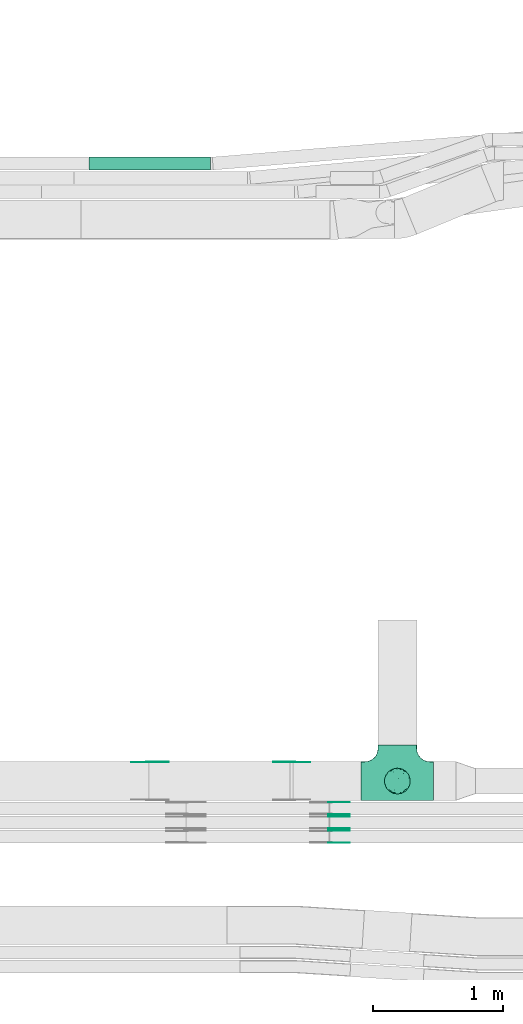
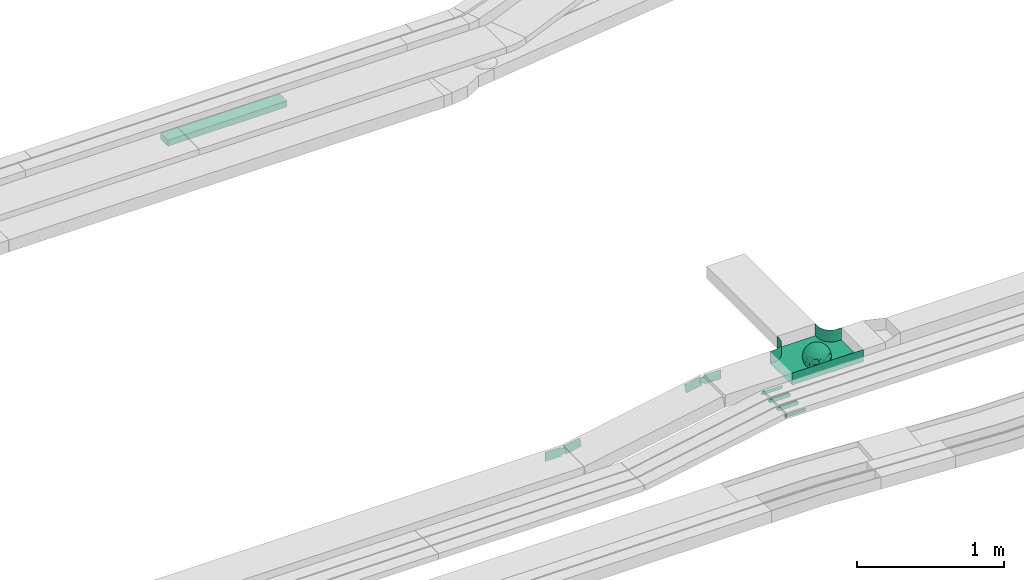
# One storey, part 12 of 32: 11 flow fittings, 1 flow segment.
"""IFC2X3 building model written with IfcOpenShell, lengths in millimetres."""

from ifc_helpers import new_model, entity, si_unit, converted_unit, derived_unit, direction, frame, frame_2d, origin, origin_2d_with_axis, place, context, subcontext, project, spatial, polyline, circle_curve, parameter, trimmed, segment, composite_curve, rectangle, outline, extrude, faceted_brep, source, transform, mapped, material, material_list, type_object, type_shapes, element, save


model = new_model("IFC2X3")

# Units and contexts
model_context = context("Model", 3, precision=0.01, world=origin(), true_north=direction((6.12303176911189e-17, 1.0)))
body_context = subcontext(model_context, "Body", "Model", "MODEL_VIEW")
ifc_project = project(units=[si_unit("LENGTHUNIT", "METRE", prefix="MILLI"), si_unit("AREAUNIT", "SQUARE_METRE"), si_unit("VOLUMEUNIT", "CUBIC_METRE"), converted_unit("PLANEANGLEUNIT", "DEGREE", entity("IfcRatioMeasure", 0.0174532925199433), si_unit("PLANEANGLEUNIT", "RADIAN"), dimensions=[0, 0, 0, 0, 0, 0, 0]), si_unit("MASSUNIT", "GRAM", prefix="KILO"), derived_unit("MASSDENSITYUNIT", [(si_unit("MASSUNIT", "GRAM", prefix="KILO"), 1), (si_unit("LENGTHUNIT", "METRE"), -3)]), derived_unit("MOMENTOFINERTIAUNIT", [(si_unit("LENGTHUNIT", "METRE"), 4)]), si_unit("TIMEUNIT", "SECOND"), si_unit("FREQUENCYUNIT", "HERTZ"), si_unit("THERMODYNAMICTEMPERATUREUNIT", "DEGREE_CELSIUS"), derived_unit("THERMALTRANSMITTANCEUNIT", [(si_unit("MASSUNIT", "GRAM", prefix="KILO"), 1), (si_unit("THERMODYNAMICTEMPERATUREUNIT", "KELVIN"), -1), (si_unit("TIMEUNIT", "SECOND"), -3)]), derived_unit("VOLUMETRICFLOWRATEUNIT", [(si_unit("LENGTHUNIT", "METRE"), 3), (si_unit("TIMEUNIT", "SECOND"), -1)]), derived_unit("MASSFLOWRATEUNIT", [(si_unit("MASSUNIT", "GRAM", prefix="KILO"), 1), (si_unit("TIMEUNIT", "SECOND"), -1)]), derived_unit("ROTATIONALFREQUENCYUNIT", [(si_unit("TIMEUNIT", "SECOND"), -1)]), si_unit("ELECTRICCURRENTUNIT", "AMPERE"), si_unit("ELECTRICVOLTAGEUNIT", "VOLT"), si_unit("POWERUNIT", "WATT"), si_unit("FORCEUNIT", "NEWTON", prefix="KILO"), si_unit("ILLUMINANCEUNIT", "LUX"), si_unit("LUMINOUSFLUXUNIT", "LUMEN"), si_unit("LUMINOUSINTENSITYUNIT", "CANDELA"), derived_unit("USERDEFINED", [(si_unit("MASSUNIT", "GRAM", prefix="KILO"), -1), (si_unit("LENGTHUNIT", "METRE"), -2), (si_unit("TIMEUNIT", "SECOND"), 3), (si_unit("LUMINOUSFLUXUNIT", "LUMEN"), 1)]), derived_unit("LINEARVELOCITYUNIT", [(si_unit("LENGTHUNIT", "METRE"), 1), (si_unit("TIMEUNIT", "SECOND"), -1)]), si_unit("PRESSUREUNIT", "PASCAL"), derived_unit("USERDEFINED", [(si_unit("LENGTHUNIT", "METRE"), -2), (si_unit("MASSUNIT", "GRAM", prefix="KILO"), 1), (si_unit("TIMEUNIT", "SECOND"), -2)]), derived_unit("LINEARFORCEUNIT", [(si_unit("MASSUNIT", "GRAM", prefix="KILO"), 1), (si_unit("LENGTHUNIT", "METRE"), 1), (si_unit("TIMEUNIT", "SECOND"), -2), (si_unit("LENGTHUNIT", "METRE"), -1)]), derived_unit("PLANARFORCEUNIT", [(si_unit("MASSUNIT", "GRAM", prefix="KILO"), 1), (si_unit("LENGTHUNIT", "METRE"), 1), (si_unit("TIMEUNIT", "SECOND"), -2), (si_unit("LENGTHUNIT", "METRE"), -2)])], contexts=[model_context])

# Site, building, storey
site_placement = place(None, origin())
site = spatial("IfcSite", under=ifc_project, at=site_placement, CompositionType="ELEMENT")
building_placement = place(site_placement, origin())
building = spatial("IfcBuilding", under=site, at=building_placement, CompositionType="ELEMENT")
storey_placement = place(building_placement, frame((0.0, 0.0, 8100.0)))
storey = spatial("IfcBuildingStorey", under=building, at=storey_placement, CompositionType="ELEMENT", Elevation=8100.0)

# Flow segment
cable_carrier_segment_type = type_object("IfcCableCarrierSegmentType", PredefinedType="CABLETRAYSEGMENT")
flow_segment_placement = place(storey_placement, frame((24709.61, 14712.28, 2570.0)))
element("IfcFlowSegment", 1, at=flow_segment_placement, inside=storey, type_object=cable_carrier_segment_type, context=body_context, shape_type="SweptSolid", body=[
    extrude(rectangle(XDim=937.962058538578, YDim=99.9999999999989, at=origin_2d_with_axis()), frame((468.98, 50.0, 0.0)), (0.0, 0.0, 1.0), 50.0000000000016),
])

# Flow fittings
ifc_material_1 = material()
ifc_material_2 = material()
ifc_material_list = material_list([ifc_material_1, ifc_material_2])
cable_carrier_fitting_type_1 = type_object("IfcCableCarrierFittingType", PredefinedType="NOTDEFINED", material=ifc_material_1)
shared_shape_1 = source(origin(), body_context, "Body", "Brep", [
    faceted_brep([(76.48, -37.8, -52.17), (89.29, -26.17, -36.65), (85.27, -46.63, -23.54), (-17.29, -34.78, -92.15), (0.0, -44.16, -89.72), (-24.64, -51.58, -82.05), (76.33, -15.08, -62.82), (55.58, -29.55, -77.71), (-17.1, 96.98, 0.0), (-18.67, 88.89, -41.84), (-33.9, 89.53, -28.9), (-45.46, -10.48, -88.45), (-19.82, 5.04, -97.89), (-23.66, -16.13, -95.81), (92.54, 33.68, 0.0), (85.28, 45.77, -25.16), (86.6, 50.0, 0.0), (49.24, -85.29, 0.0), (62.2, -72.19, -30.32), (64.28, -76.6, 0.0), (97.17, -8.72, -21.95), (90.76, 0.0, -41.98), (96.14, 14.4, -23.44), (98.48, 17.36, 0.0), (98.48, 0.0, 0.0), (79.01, 8.48, -60.71), (76.48, 37.8, -52.17), (87.7, 23.44, -41.95), (29.16, -37.6, -87.95), (20.3, -63.77, -74.31), (-69.62, 53.19, -48.2), (-47.21, 56.75, -67.46), (-61.6, 43.47, -65.69), (29.45, 71.32, -63.61), (47.21, 56.75, -67.46), (30.04, 49.65, -81.44), (-49.67, -77.09, -39.87), (-34.2, -93.97, 0.0), (-49.24, -85.29, 0.0), (61.4, 65.14, -44.57), (74.68, 59.14, -30.41), (61.95, 44.54, -64.64), (28.77, -89.42, -34.29), (34.2, -93.97, 0.0), (25.65, -95.48, 0.0), (17.1, -96.98, 0.0), (-64.28, -76.6, 0.0), (-75.44, -63.3, 0.0), (-74.75, -61.55, -24.99), (7.5, -83.69, -54.22), (36.49, -70.37, -60.97), (-76.48, -37.8, -52.17), (-87.07, -22.49, -43.74), (-79.06, -6.54, -60.88), (63.53, 0.0, -77.22), (-63.53, 0.0, -77.22), (-81.93, 16.04, -55.05), (-98.48, -17.36, 0.0), (-95.57, -17.05, -24.0), (-92.54, -33.68, 0.0), (65.86, 23.41, -71.51), (-19.3, 70.27, -68.49), (-44.33, 79.42, -41.56), (-76.48, 37.8, -52.17), (-45.05, 37.36, -81.09), (-67.2, 22.41, -70.59), (45.89, 15.54, -87.48), (-67.14, -22.46, -70.63), (-97.69, 5.09, -20.78), (-90.76, 0.0, -41.98), (-92.54, 33.68, 0.0), (-92.15, 27.2, -27.72), (28.87, 87.52, -38.83), (7.5, 83.69, -54.22), (1.23, 95.73, -28.9), (3.52, -95.84, -28.34), (-8.55, -98.49, 0.0), (-12.28, -96.15, -24.6), (75.44, 63.3, 0.0), (64.28, 76.6, 0.0), (75.44, -63.3, 0.0), (86.6, -50.0, 0.0), (-75.44, 63.3, 0.0), (-84.89, 46.81, -24.54), (-86.6, 50.0, 0.0), (-65.62, -61.39, -43.88), (-47.21, -56.75, -67.46), (-85.24, -44.68, -27.17), (46.02, 37.17, -80.63), (-63.18, 67.68, -37.79), (-7.15, -67.62, -73.33), (31.54, -5.3, -94.75), (9.85, -20.5, -97.38), (0.0, 13.3, -99.11), (49.35, -11.18, -86.25), (92.54, -33.68, 0.0), (98.48, -17.36, 0.0), (49.24, 85.29, 0.0), (46.4, 79.11, -39.86), (34.2, 93.97, 0.0), (-53.11, 15.12, -83.37), (64.53, -54.17, -53.86), (47.21, -56.75, -67.46), (22.89, 27.57, -93.36), (74.68, -59.14, -30.41), (46.4, -79.11, -39.86), (-15.74, 23.19, -95.99), (2.81, 33.98, -94.01), (9.21, 52.39, -84.68), (9.73, 69.75, -71.0), (17.1, 96.98, 0.0), (-5.62, -90.16, -42.88), (0.0, -100.0, 0.0), (-25.13, -93.37, -25.51), (-25.95, -84.88, -46.06), (-17.1, -96.98, 0.0), (-10.24, -80.78, -58.05), (-31.24, -69.76, -64.48), (-42.19, -33.64, -84.2), (-35.78, 18.55, -91.52), (-61.62, -43.52, -65.64), (-17.34, 40.89, -89.6), (-29.1, 55.69, -77.79), (-10.66, 57.03, -81.45), (-59.77, -75.57, -26.75), (-86.6, -50.0, 0.0), (-98.48, 0.0, 0.0), (-98.48, 17.36, 0.0), (-74.77, 60.7, -26.92), (-64.28, 76.6, 0.0), (-49.24, 85.29, 0.0), (-34.2, 93.97, 0.0), (0.0, 100.0, 0.0), (-76.48, -37.8, 52.17), (-89.29, -26.17, 36.65), (-85.27, -46.63, 23.54), (17.29, -34.78, 92.15), (0.0, -44.16, 89.72), (24.64, -51.58, 82.05), (-76.33, -15.08, 62.82), (-55.58, -29.55, 77.71), (18.67, 88.89, 41.84), (33.9, 89.53, 28.9), (17.34, 40.89, 89.6), (15.74, 23.19, 95.99), (35.78, 18.55, 91.52), (-85.28, 45.77, 25.16), (-62.2, -72.19, 30.32), (-97.17, -8.72, 21.95), (-96.14, 14.4, 23.44), (-79.01, 8.48, 60.71), (-76.48, 37.8, 52.17), (-87.7, 23.44, 41.95), (-29.16, -37.6, 87.95), (-20.3, -63.77, 74.31), (69.62, 53.19, 48.2), (47.21, 56.75, 67.46), (61.6, 43.47, 65.69), (-61.4, 65.14, 44.57), (49.27, -77.35, 39.88), (-74.68, 59.14, 30.41), (-61.95, 44.54, 64.64), (-7.5, -83.69, 54.22), (-36.49, -70.37, 60.97), (-28.77, -89.42, 34.29), (74.74, -61.65, 24.74), (3.0, -95.52, 29.45), (-13.47, -92.75, 34.88), (76.48, -37.8, 52.17), (87.07, -22.49, 43.74), (79.06, -6.54, 60.88), (-63.53, 0.0, 77.22), (63.53, 0.0, 77.22), (81.93, 16.04, 55.05), (95.57, -17.05, 24.0), (-65.86, 23.41, 71.51), (19.3, 70.27, 68.49), (44.33, 79.42, 41.56), (76.48, 37.8, 52.17), (45.05, 37.36, 81.09), (67.2, 22.41, 70.59), (-45.89, 15.54, 87.48), (67.14, -22.46, 70.63), (97.69, 5.09, 20.78), (90.76, 0.0, 41.98), (92.15, 27.2, 27.72), (-28.87, 87.52, 38.83), (-7.5, 83.69, 54.22), (-1.23, 95.73, 28.9), (7.15, -67.62, 73.33), (30.04, -71.02, 63.66), (-90.76, 0.0, 41.98), (84.89, 46.81, 24.54), (65.66, -61.85, 43.17), (47.21, -56.75, 67.46), (85.24, -44.68, 27.17), (-30.04, 49.65, 81.44), (-47.21, 56.75, 67.46), (-46.02, 37.17, 80.63), (63.18, 67.68, 37.79), (-31.54, -5.3, 94.75), (-9.85, -20.5, 97.38), (0.0, 13.3, 99.11), (-49.35, -11.18, 86.25), (-46.4, 79.11, 39.86), (-29.45, 71.32, 63.61), (24.31, -93.79, 24.74), (-64.53, -54.17, 53.86), (-47.21, -56.75, 67.46), (-22.89, 27.57, 93.36), (-46.4, -79.11, 39.86), (-74.68, -59.14, 30.41), (19.82, 5.04, 97.89), (-2.81, 33.98, 94.01), (-9.21, 52.39, 84.68), (-9.73, 69.75, 71.0), (9.65, -80.54, 58.49), (23.47, -86.31, 44.72), (35.11, -89.62, 27.11), (42.19, -33.64, 84.2), (23.66, -16.13, 95.81), (45.46, -10.48, 88.45), (61.62, -43.52, 65.64), (29.1, 55.69, 77.79), (10.66, 57.03, 81.45), (59.35, -75.82, 26.99), (74.77, 60.7, 26.92), (53.11, 15.12, 83.37)], [[[0, 1, 2]], [[3, 4, 5]], [[6, 0, 7]], [[8, 9, 10]], [[11, 12, 13]], [[14, 15, 16]], [[17, 18, 19]], [[20, 21, 22]], [[22, 23, 24]], [[25, 26, 27]], [[4, 28, 29]], [[30, 31, 32]], [[33, 34, 35]], [[36, 37, 38]], [[39, 40, 41]], [[42, 43, 44, 45]], [[46, 47, 48]], [[49, 50, 42]], [[51, 52, 53]], [[54, 25, 6]], [[55, 53, 56]], [[57, 58, 59]], [[26, 25, 60]], [[61, 31, 62]], [[32, 63, 30]], [[64, 65, 32]], [[54, 66, 60]], [[53, 67, 51]], [[58, 68, 69]], [[68, 70, 71]], [[72, 73, 74]], [[75, 76, 77]], [[6, 7, 54]], [[24, 20, 22]], [[78, 40, 79]], [[15, 26, 40]], [[1, 21, 20]], [[80, 2, 81]], [[63, 56, 71]], [[82, 83, 84]], [[36, 85, 86]], [[87, 58, 52]], [[35, 34, 88]], [[62, 31, 89]], [[42, 75, 49]], [[4, 29, 90]], [[91, 92, 93]], [[7, 94, 54]], [[6, 1, 0]], [[95, 81, 2]], [[24, 96, 20]], [[1, 20, 95]], [[1, 95, 2]], [[27, 22, 21]], [[15, 14, 22]], [[25, 27, 21]], [[15, 78, 16]], [[41, 40, 26]], [[40, 78, 15]], [[39, 97, 79]], [[97, 98, 99]], [[40, 39, 79]], [[33, 73, 72]], [[21, 1, 6]], [[25, 54, 60]], [[64, 100, 65]], [[26, 15, 27]], [[6, 25, 21]], [[0, 101, 7]], [[102, 28, 7]], [[92, 91, 28]], [[94, 28, 91]], [[88, 34, 41]], [[54, 94, 66]], [[41, 26, 60]], [[103, 91, 93]], [[88, 41, 60]], [[20, 96, 95]], [[101, 18, 102]], [[104, 80, 19]], [[101, 0, 104]], [[18, 105, 102]], [[43, 42, 105]], [[17, 43, 105]], [[29, 28, 102]], [[28, 4, 92]], [[105, 50, 102]], [[90, 29, 49]], [[88, 60, 66]], [[41, 34, 39]], [[34, 98, 39]], [[97, 39, 98]], [[103, 66, 91]], [[88, 66, 103]], [[12, 106, 93]], [[33, 98, 34]], [[107, 103, 93]], [[35, 103, 108]], [[103, 35, 88]], [[33, 109, 73]], [[109, 35, 108]], [[110, 72, 74]], [[72, 110, 99]], [[98, 33, 72]], [[99, 98, 72]], [[80, 104, 2]], [[0, 2, 104]], [[101, 104, 18]], [[7, 101, 102]], [[19, 18, 104]], [[105, 18, 17]], [[77, 111, 75]], [[75, 45, 112]], [[113, 114, 111]], [[115, 77, 76]], [[36, 114, 37]], [[90, 5, 4]], [[75, 42, 45]], [[50, 49, 29]], [[49, 116, 90]], [[5, 117, 86]], [[90, 116, 117]], [[118, 13, 3]], [[118, 5, 86]], [[11, 119, 12]], [[67, 120, 51]], [[11, 13, 118]], [[65, 55, 56]], [[121, 122, 123]], [[90, 117, 5]], [[51, 120, 85]], [[117, 36, 86]], [[36, 117, 114]], [[46, 48, 124]], [[38, 124, 36]], [[85, 124, 48]], [[87, 125, 59]], [[125, 87, 47]], [[48, 51, 85]], [[68, 57, 126, 127]], [[59, 58, 87]], [[58, 69, 52]], [[53, 52, 69]], [[87, 52, 51]], [[56, 53, 69]], [[53, 55, 67]], [[71, 56, 69]], [[56, 63, 65]], [[71, 69, 68]], [[128, 129, 89]], [[11, 67, 55]], [[120, 118, 86]], [[32, 65, 63]], [[100, 55, 65]], [[118, 120, 67]], [[85, 120, 86]], [[129, 128, 82]], [[64, 32, 31]], [[62, 130, 131]], [[130, 62, 89]], [[9, 73, 61]], [[10, 62, 131]], [[109, 61, 73]], [[73, 9, 74]], [[64, 121, 119]], [[122, 61, 123]], [[64, 119, 100]], [[64, 31, 122]], [[107, 108, 103]], [[47, 87, 48]], [[51, 48, 87]], [[57, 68, 58]], [[64, 122, 121]], [[89, 129, 130]], [[67, 11, 118]], [[11, 55, 100]], [[82, 128, 83]], [[30, 128, 89]], [[83, 63, 71]], [[63, 83, 128]], [[84, 83, 71]], [[10, 61, 62]], [[74, 8, 132]], [[8, 74, 9]], [[110, 74, 132]], [[3, 92, 4]], [[92, 13, 12]], [[22, 27, 15]], [[14, 23, 22]], [[11, 100, 119]], [[128, 30, 63]], [[31, 30, 89]], [[28, 94, 7]], [[66, 94, 91]], [[42, 50, 105]], [[29, 102, 50]], [[106, 107, 93]], [[123, 107, 121]], [[35, 109, 33]], [[109, 108, 123]], [[75, 112, 76]], [[113, 77, 115]], [[114, 116, 111]], [[115, 37, 113]], [[37, 114, 113]], [[49, 75, 111]], [[117, 116, 114]], [[111, 77, 113]], [[49, 111, 116]], [[118, 3, 5]], [[92, 3, 13]], [[106, 119, 121]], [[92, 12, 93]], [[119, 106, 12]], [[107, 106, 121]], [[46, 124, 38]], [[85, 36, 124]], [[70, 68, 127]], [[70, 84, 71]], [[31, 61, 122]], [[109, 123, 61]], [[107, 123, 108]], [[8, 10, 131]], [[61, 10, 9]], [[133, 134, 135]], [[136, 137, 138]], [[139, 133, 140]], [[110, 141, 142]], [[143, 144, 145]], [[70, 146, 84]], [[38, 147, 46]], [[126, 57, 148]], [[149, 127, 126]], [[150, 151, 152]], [[137, 153, 154]], [[155, 156, 157]], [[130, 129, 158]], [[159, 43, 17]], [[158, 160, 161]], [[162, 163, 164]], [[19, 80, 165]], [[166, 167, 115]], [[168, 169, 170]], [[171, 150, 139]], [[172, 170, 173]], [[96, 174, 95]], [[151, 150, 175]], [[176, 156, 177]], [[157, 178, 155]], [[179, 180, 157]], [[171, 181, 175]], [[170, 182, 168]], [[174, 183, 184]], [[185, 23, 14, 16]], [[186, 187, 188]], [[138, 189, 190]], [[139, 140, 171]], [[126, 148, 149]], [[82, 160, 129]], [[146, 151, 160]], [[134, 191, 148]], [[47, 135, 125]], [[178, 173, 185]], [[78, 192, 16]], [[159, 193, 194]], [[195, 174, 169]], [[196, 197, 198]], [[177, 156, 199]], [[166, 112, 45]], [[154, 189, 137]], [[200, 201, 202]], [[140, 203, 171]], [[191, 149, 148]], [[59, 125, 135]], [[133, 139, 134]], [[134, 148, 59]], [[134, 59, 135]], [[152, 149, 191]], [[146, 70, 149]], [[150, 152, 191]], [[146, 82, 84]], [[161, 160, 151]], [[160, 82, 146]], [[204, 131, 130]], [[186, 205, 187]], [[160, 158, 129]], [[197, 196, 205]], [[191, 134, 139]], [[150, 171, 175]], [[45, 206, 166]], [[151, 146, 152]], [[139, 150, 191]], [[133, 207, 140]], [[208, 153, 140]], [[201, 200, 153]], [[203, 153, 200]], [[198, 197, 161]], [[171, 203, 181]], [[161, 151, 175]], [[209, 200, 202]], [[198, 161, 175]], [[148, 57, 59]], [[38, 37, 210]], [[211, 47, 46]], [[207, 133, 211]], [[147, 210, 208]], [[210, 37, 164]], [[208, 207, 147]], [[154, 153, 208]], [[153, 137, 201]], [[210, 163, 208]], [[189, 154, 162]], [[198, 175, 181]], [[161, 197, 158]], [[197, 204, 158]], [[130, 158, 204]], [[209, 181, 200]], [[198, 181, 209]], [[212, 144, 202]], [[205, 204, 197]], [[213, 209, 202]], [[196, 209, 214]], [[209, 196, 198]], [[205, 215, 187]], [[215, 196, 214]], [[8, 186, 188]], [[186, 8, 131]], [[204, 205, 186]], [[131, 204, 186]], [[47, 211, 135]], [[133, 135, 211]], [[207, 211, 147]], [[140, 207, 208]], [[46, 147, 211]], [[210, 147, 38]], [[166, 115, 76, 112]], [[115, 164, 37]], [[163, 162, 154]], [[216, 166, 217]], [[138, 137, 189]], [[162, 216, 189]], [[218, 44, 43]], [[44, 218, 206]], [[189, 216, 190]], [[219, 220, 136]], [[219, 138, 194]], [[221, 145, 212]], [[182, 222, 168]], [[221, 220, 219]], [[180, 172, 173]], [[143, 223, 224]], [[168, 222, 193]], [[194, 138, 190]], [[190, 159, 194]], [[190, 217, 218]], [[19, 165, 225]], [[17, 225, 159]], [[193, 225, 165]], [[195, 81, 95]], [[81, 195, 80]], [[165, 168, 193]], [[183, 96, 24, 23]], [[95, 174, 195]], [[174, 184, 169]], [[170, 169, 184]], [[195, 169, 168]], [[173, 170, 184]], [[170, 172, 182]], [[185, 173, 184]], [[173, 178, 180]], [[185, 184, 183]], [[226, 79, 199]], [[221, 182, 172]], [[222, 219, 194]], [[157, 180, 178]], [[227, 172, 180]], [[219, 222, 182]], [[193, 222, 194]], [[79, 226, 78]], [[179, 157, 156]], [[177, 97, 99]], [[97, 177, 199]], [[141, 187, 176]], [[142, 177, 99]], [[215, 176, 187]], [[187, 141, 188]], [[179, 143, 145]], [[223, 176, 224]], [[179, 145, 227]], [[179, 156, 223]], [[213, 214, 209]], [[96, 183, 174]], [[185, 183, 23]], [[80, 195, 165]], [[168, 165, 195]], [[199, 79, 97]], [[182, 221, 219]], [[221, 172, 227]], [[78, 226, 192]], [[155, 226, 199]], [[192, 178, 185]], [[178, 192, 226]], [[16, 192, 185]], [[142, 176, 177]], [[188, 110, 132]], [[110, 188, 141]], [[8, 188, 132]], [[136, 201, 137]], [[201, 220, 212]], [[149, 152, 146]], [[70, 127, 149]], [[167, 162, 164]], [[179, 227, 180]], [[221, 227, 145]], [[226, 155, 178]], [[156, 155, 199]], [[153, 203, 140]], [[181, 203, 200]], [[164, 163, 210]], [[154, 208, 163]], [[144, 213, 202]], [[224, 213, 143]], [[196, 215, 205]], [[215, 214, 224]], [[166, 216, 162]], [[190, 216, 217]], [[218, 217, 206]], [[43, 159, 218]], [[190, 218, 159]], [[166, 206, 217]], [[44, 206, 45]], [[219, 136, 138]], [[201, 136, 220]], [[201, 212, 202]], [[221, 212, 220]], [[145, 144, 212]], [[213, 144, 143]], [[19, 225, 17]], [[193, 159, 225]], [[179, 223, 143]], [[156, 176, 223]], [[215, 224, 176]], [[213, 224, 214]], [[110, 142, 99]], [[176, 142, 141]], [[115, 167, 164]], [[166, 162, 167]]]),
    faceted_brep([(-153.41, -224.12, 50.0), (-150.0, -250.0, 50.0), (-150.0, -280.0, 50.0), (-149.2, -280.0, 50.0), (-149.2, -250.0, 50.0), (-152.63, -223.91, 50.0), (-162.7, -199.6, 50.0), (-178.72, -178.72, 50.0), (-199.6, -162.7, 50.0), (-223.91, -152.63, 50.0), (-250.0, -149.2, 50.0), (-280.0, -149.2, 50.0), (-280.0, -150.0, 50.0), (-250.0, -150.0, 50.0), (-224.12, -153.41, 50.0), (-200.0, -163.4, 50.0), (-179.29, -179.29, 50.0), (-163.4, -200.0, 50.0), (280.0, -150.0, 50.0), (280.0, -149.2, 50.0), (250.0, -149.2, 50.0), (223.91, -152.63, 50.0), (199.6, -162.7, 50.0), (178.72, -178.72, 50.0), (162.7, -199.6, 50.0), (152.63, -223.91, 50.0), (149.2, -250.0, 50.0), (149.2, -280.0, 50.0), (150.0, -280.0, 50.0), (150.0, -250.0, 50.0), (153.41, -224.12, 50.0), (163.4, -200.0, 50.0), (179.29, -179.29, 50.0), (200.0, -163.4, 50.0), (224.12, -153.41, 50.0), (250.0, -150.0, 50.0), (280.0, 149.2, 50.0), (280.0, 150.0, 50.0), (-280.0, 150.0, 50.0), (-280.0, 149.2, 50.0), (-280.0, -150.0, -50.0), (-280.0, 150.0, -50.0), (280.0, 150.0, -50.0), (280.0, -150.0, -50.0), (250.0, -150.0, -50.0), (224.12, -153.41, -50.0), (200.0, -163.4, -50.0), (179.29, -179.29, -50.0), (163.4, -200.0, -50.0), (153.41, -224.12, -50.0), (150.0, -250.0, -50.0), (150.0, -280.0, -50.0), (-150.0, -280.0, -50.0), (-150.0, -250.0, -50.0), (-153.41, -224.12, -50.0), (-163.4, -200.0, -50.0), (-179.29, -179.29, -50.0), (-200.0, -163.4, -50.0), (-224.12, -153.41, -50.0), (-250.0, -150.0, -50.0), (-150.0, -250.0, -49.2), (149.2, -280.0, -49.2), (-149.2, -280.0, -49.2), (-149.2, -250.0, -49.2), (-250.0, -149.2, -49.2), (-280.0, -149.2, -49.2), (280.0, -149.2, -49.2), (250.0, -149.2, -49.2), (-280.0, 149.2, -49.2), (-250.0, -150.0, -49.2), (250.0, -150.0, -49.2), (280.0, 149.2, -49.2), (149.2, -250.0, -49.2), (150.0, -250.0, -49.2), (-223.91, -152.63, -49.2), (-199.6, -162.7, -49.2), (-178.72, -178.72, -49.2), (-162.7, -199.6, -49.2), (-152.63, -223.91, -49.2), (152.63, -223.91, -49.2), (162.7, -199.6, -49.2), (178.72, -178.72, -49.2), (199.6, -162.7, -49.2), (223.91, -152.63, -49.2)], [[[0, 1, 2, 3, 4, 5, 6, 7, 8, 9, 10, 11, 12, 13, 14, 15, 16, 17]], [[18, 19, 20, 21, 22, 23, 24, 25, 26, 27, 28, 29, 30, 31, 32, 33, 34, 35]], [[36, 37, 38, 39]], [[40, 41, 42, 43, 44, 45, 46, 47, 48, 49, 50, 51, 52, 53, 54, 55, 56, 57, 58, 59]], [[2, 1, 60, 53, 52]], [[3, 2, 52, 51, 28, 27, 61, 62]], [[4, 3, 62, 63]], [[11, 10, 64, 65]], [[20, 19, 66, 67]], [[39, 38, 41, 40, 12, 11, 65, 68]], [[13, 12, 40, 59, 69]], [[18, 35, 70, 44, 43]], [[19, 18, 43, 42, 37, 36, 71, 66]], [[27, 26, 72, 61]], [[29, 28, 51, 50, 73]], [[38, 37, 42, 41]], [[36, 39, 68, 71]], [[68, 65, 64, 74, 75, 76, 77, 78, 63, 62, 61, 72, 79, 80, 81, 82, 83, 67, 66, 71]], [[14, 13, 69, 59, 58]], [[15, 14, 58, 57]], [[57, 56, 16, 15]], [[17, 16, 56, 55]], [[0, 17, 55, 54]], [[1, 0, 54, 53, 60]], [[5, 78, 77, 6]], [[6, 77, 76, 7]], [[63, 78, 5, 4]], [[8, 75, 74, 9]], [[9, 74, 64, 10]], [[7, 76, 75, 8]], [[21, 83, 82, 22]], [[22, 82, 81, 23]], [[67, 83, 21, 20]], [[24, 80, 79, 25]], [[25, 79, 72, 26]], [[23, 81, 80, 24]], [[30, 29, 73, 50, 49]], [[31, 30, 49, 48]], [[32, 31, 48, 47]], [[34, 33, 46, 45]], [[34, 45, 44, 70, 35]], [[46, 33, 32, 47]]]),
])
type_shapes(cable_carrier_fitting_type_1, [shared_shape_1])
flow_fitting_placement = place(storey_placement, frame((27091.01, 9995.0, 2850.0), z_axis=(0.0, 0.0, 1.0), x_axis=(-1.0, 0.0, 0.0)))
element("IfcFlowFitting", 2, at=flow_fitting_placement, inside=storey, type_object=cable_carrier_fitting_type_1, material=ifc_material_list, Name="470_DKC_S5_T", context=body_context, shape_type="MappedRepresentation", body=[
    mapped(shared_shape_1, transform((0.0, 0.0, 0.0), scale=1.0)),
])
ifc_material_3 = material(Name="G")
cable_carrier_fitting_type_2 = type_object("IfcCableCarrierFittingType", PredefinedType="NOTDEFINED", material=ifc_material_3)
shared_shape_2 = source(origin(), body_context, "Body", "SweptSolid", [
    extrude(outline(composite_curve([segment(trimmed(circle_curve(frame_2d((-44.59, 0.0), x_axis=(1.0, 0.0)), 12.5), [parameter(90.0000000000007)], [parameter(270.0)], True, "PARAMETER"), True, "CONTINUOUS"), segment(polyline([(-44.59, -12.5), (-33.09, -12.5)]), True, "CONTINUOUS"), segment(polyline([(-33.09, -12.5), (-31.23, -14.5)]), True, "CONTINUOUS"), segment(polyline([(-31.23, -14.5), (108.91, -14.5)]), True, "CONTINUOUS"), segment(polyline([(108.91, -14.5), (108.91, 14.5)]), True, "CONTINUOUS"), segment(polyline([(108.91, 14.5), (-31.23, 14.5)]), True, "CONTINUOUS"), segment(polyline([(-31.23, 14.5), (-33.09, 12.5)]), True, "CONTINUOUS"), segment(polyline([(-33.09, 12.5), (-44.59, 12.5)]), True, "CONTINUOUS")], self_intersect=False)), frame((44.59, 0.0, 0.0), z_axis=(0.0, 0.0, -1.0), x_axis=(1.0, 0.0, 0.0)), (0.0, 0.0, -1.0), 2.0),
])
type_shapes(cable_carrier_fitting_type_2, [shared_shape_2])
for number, where, z_axis, x_axis in (
    (3, (26571.19, 9610.94, 2825.0), (0.0, 1.0, 0.0), (1.0, 0.0, 0.0)),
    (4, (26570.55, 9720.94, 2825.0), (0.0, 1.0, 0.0), (1.0, 0.0, 0.0)),
    (5, (26570.71, 9830.46, 2825.0), (0.0, 1.0, 0.0), (1.0, 0.0, 0.0)),
):
    element("IfcFlowFitting", number, at=place(storey_placement, frame(where, z_axis=z_axis, x_axis=x_axis)), inside=storey, type_object=cable_carrier_fitting_type_2, material=ifc_material_3, context=body_context, shape_type="MappedRepresentation", body=[
        mapped(shared_shape_2, transform((0.0, 0.0, 0.0), scale=1.0)),
    ])
cable_carrier_fitting_type_3 = type_object("IfcCableCarrierFittingType", PredefinedType="NOTDEFINED", material=ifc_material_3)
shared_shape_3 = source(origin(), body_context, "Body", "SweptSolid", [
    extrude(outline(composite_curve([segment(trimmed(circle_curve(frame_2d((-44.59, 0.0), x_axis=(1.0, 0.0)), 12.5), [parameter(90.0000000000007)], [parameter(270.0)], True, "PARAMETER"), True, "CONTINUOUS"), segment(polyline([(-44.59, -12.5), (-33.09, -12.5)]), True, "CONTINUOUS"), segment(polyline([(-33.09, -12.5), (-31.23, -14.5)]), True, "CONTINUOUS"), segment(polyline([(-31.23, -14.5), (108.91, -14.5)]), True, "CONTINUOUS"), segment(polyline([(108.91, -14.5), (108.91, 14.5)]), True, "CONTINUOUS"), segment(polyline([(108.91, 14.5), (-31.23, 14.5)]), True, "CONTINUOUS"), segment(polyline([(-31.23, 14.5), (-33.09, 12.5)]), True, "CONTINUOUS"), segment(polyline([(-33.09, 12.5), (-44.59, 12.5)]), True, "CONTINUOUS")], self_intersect=False)), frame((44.59, 0.0, 0.0)), (0.0, 0.0, 1.0), 2.0),
])
type_shapes(cable_carrier_fitting_type_3, [shared_shape_3])
for number, where, z_axis, x_axis in (
    (6, (26571.19, 9520.02, 2825.0), (0.0, -1.0, 0.0), (1.0, 0.0, 0.0)),
    (7, (26570.55, 9630.02, 2825.0), (0.0, -1.0, 0.0), (1.0, 0.0, 0.0)),
    (8, (26570.71, 9739.54, 2825.0), (0.0, -1.0, 0.0), (1.0, 0.0, 0.0)),
):
    element("IfcFlowFitting", number, at=place(storey_placement, frame(where, z_axis=z_axis, x_axis=x_axis)), inside=storey, type_object=cable_carrier_fitting_type_3, material=ifc_material_3, context=body_context, shape_type="MappedRepresentation", body=[
        mapped(shared_shape_3, transform((0.0, 0.0, 0.0), scale=1.0)),
    ])
cable_carrier_fitting_type_4 = type_object("IfcCableCarrierFittingType", PredefinedType="NOTDEFINED", material=ifc_material_3)
shared_shape_4 = source(origin(), body_context, "Body", "SweptSolid", [
    extrude(outline(composite_curve([segment(trimmed(circle_curve(frame_2d((-41.47, 0.0), x_axis=(1.0, 0.0)), 25.0), [parameter(90.0000000000007)], [parameter(270.0)], True, "PARAMETER"), True, "CONTINUOUS"), segment(polyline([(-41.47, -25.0), (-29.97, -25.0)]), True, "CONTINUOUS"), segment(polyline([(-29.97, -25.0), (-28.1, -38.5)]), True, "CONTINUOUS"), segment(polyline([(-28.1, -38.5), (99.53, -38.5)]), True, "CONTINUOUS"), segment(polyline([(99.53, -38.5), (99.53, 38.5)]), True, "CONTINUOUS"), segment(polyline([(99.53, 38.5), (-28.1, 38.5)]), True, "CONTINUOUS"), segment(polyline([(-28.1, 38.5), (-29.97, 25.0)]), True, "CONTINUOUS"), segment(polyline([(-29.97, 25.0), (-41.47, 25.0)]), True, "CONTINUOUS")], self_intersect=False)), frame((41.47, 0.0, 0.0), z_axis=(0.0, 0.0, -1.0), x_axis=(1.0, 0.0, 0.0)), (0.0, 0.0, -1.0), 2.0),
])
type_shapes(cable_carrier_fitting_type_4, [shared_shape_4])
for number, where, z_axis, x_axis in (
    (9, (25178.53, 10138.46, 2645.02), (0.0, 1.0, 0.0), (-1.0, 0.0, 0.0)),
    (10, (26278.51, 10138.46, 2850.0), (0.0, 1.0, 0.0), (1.0, 0.0, 0.0)),
):
    element("IfcFlowFitting", number, at=place(storey_placement, frame(where, z_axis=z_axis, x_axis=x_axis)), inside=storey, type_object=cable_carrier_fitting_type_4, material=ifc_material_3, context=body_context, shape_type="MappedRepresentation", body=[
        mapped(shared_shape_4, transform((0.0, 0.0, 0.0), scale=1.0)),
    ])
cable_carrier_fitting_type_5 = type_object("IfcCableCarrierFittingType", PredefinedType="NOTDEFINED", material=ifc_material_3)
shared_shape_5 = source(origin(), body_context, "Body", "SweptSolid", [
    extrude(outline(composite_curve([segment(trimmed(circle_curve(frame_2d((-41.47, 0.0), x_axis=(1.0, 0.0)), 25.0), [parameter(90.0000000000007)], [parameter(270.0)], True, "PARAMETER"), True, "CONTINUOUS"), segment(polyline([(-41.47, -25.0), (-29.97, -25.0)]), True, "CONTINUOUS"), segment(polyline([(-29.97, -25.0), (-28.1, -38.5)]), True, "CONTINUOUS"), segment(polyline([(-28.1, -38.5), (99.53, -38.5)]), True, "CONTINUOUS"), segment(polyline([(99.53, -38.5), (99.53, 38.5)]), True, "CONTINUOUS"), segment(polyline([(99.53, 38.5), (-28.1, 38.5)]), True, "CONTINUOUS"), segment(polyline([(-28.1, 38.5), (-29.97, 25.0)]), True, "CONTINUOUS"), segment(polyline([(-29.97, 25.0), (-41.47, 25.0)]), True, "CONTINUOUS")], self_intersect=False)), frame((41.47, 0.0, 0.0)), (0.0, 0.0, 1.0), 2.0),
])
type_shapes(cable_carrier_fitting_type_5, [shared_shape_5])
for number, where, z_axis, x_axis in (
    (11, (25178.53, 10140.46, 2645.02), (0.0, 1.0, 0.0), (0.983076107251628, 0.0, 0.183197618300528)),
    (12, (26278.51, 10140.46, 2850.0), (0.0, 1.0, 0.0), (-0.983076107251628, 0.0, -0.183197618300528)),
):
    element("IfcFlowFitting", number, at=place(storey_placement, frame(where, z_axis=z_axis, x_axis=x_axis)), inside=storey, type_object=cable_carrier_fitting_type_5, material=ifc_material_3, context=body_context, shape_type="MappedRepresentation", body=[
        mapped(shared_shape_5, transform((0.0, 0.0, 0.0), scale=1.0)),
    ])

save(model, "model.ifc")
